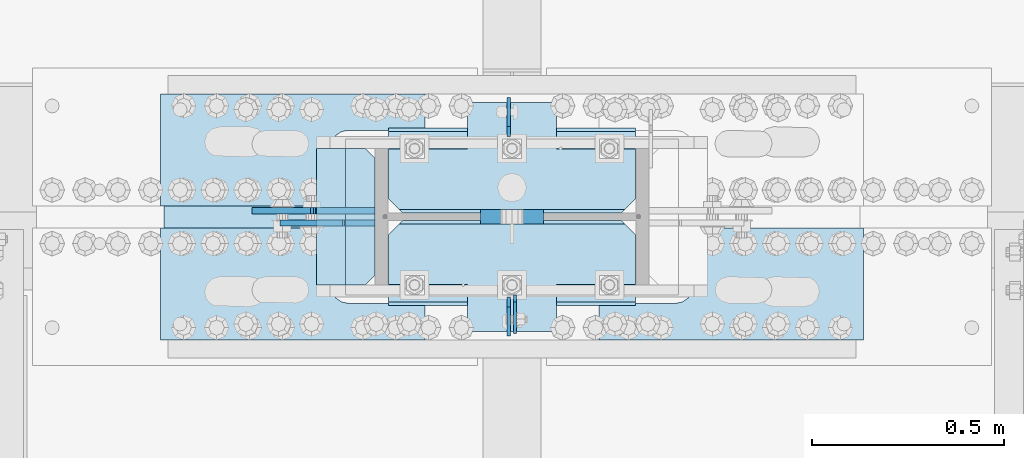
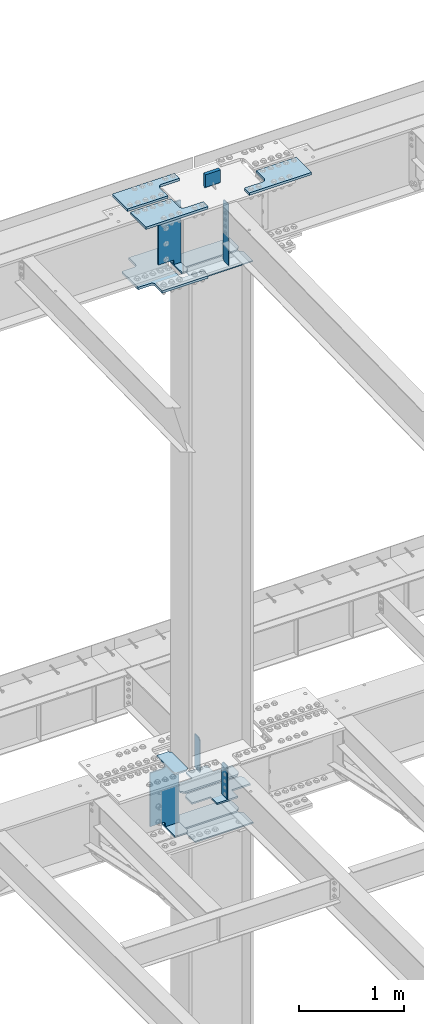
# One storey, part 1608 of 1763: 19 plates, 5 elements without a shape of their own.
"""IFC2X3 building model written with IfcOpenShell, lengths in millimetres."""

from ifc_helpers import new_model, si_unit, frame, origin_with_axes, place, context, subcontext, project, spatial, faceted_brep, material, type_object, element, aggregate, save


model = new_model("IFC2X3")

# Units and contexts
model_context = context("Model", 3, precision=1e-05, world=origin_with_axes())
body_context = subcontext(model_context, "Body", "Model", "MODEL_VIEW")
ifc_project = project(units=[si_unit("LENGTHUNIT", "METRE", prefix="MILLI"), si_unit("AREAUNIT", "SQUARE_METRE"), si_unit("VOLUMEUNIT", "CUBIC_METRE"), si_unit("MASSUNIT", "GRAM", prefix="KILO"), si_unit("TIMEUNIT", "SECOND"), si_unit("PLANEANGLEUNIT", "RADIAN"), si_unit("SOLIDANGLEUNIT", "STERADIAN"), si_unit("THERMODYNAMICTEMPERATUREUNIT", "DEGREE_CELSIUS"), si_unit("LUMINOUSINTENSITYUNIT", "LUMEN")], contexts=[model_context])

# Site, building, storey
site_placement = place(None, origin_with_axes())
site = spatial("IfcSite", under=ifc_project, at=site_placement, CompositionType="ELEMENT")
building_placement = place(site_placement, origin_with_axes())
building = spatial("IfcBuilding", under=site, at=building_placement, Name="Undefined", CompositionType="ELEMENT")
storey_placement = place(building_placement, origin_with_axes())
storey = spatial("IfcBuildingStorey", under=building, at=storey_placement, Name="Undefined", CompositionType="ELEMENT", Elevation=0.0)

# Assembly, plates
assembly_1_placement = place(storey_placement, origin_with_axes())
assembly_1 = element("IfcElementAssembly", 1, at=assembly_1_placement, inside=storey, Name="COLUMN", AssemblyPlace="NOTDEFINED", PredefinedType="RIGID_FRAME")
ifc_material_1 = material(Name="STEEL/A36")
plate_type_1 = type_object("IfcPlateType", PredefinedType="NOTDEFINED")
plate_1_placement = place(assembly_1_placement, frame((-72483.1002737632, 51917.5999999994, 11718.1532534164), z_axis=(0.0, -1.0, 0.0), x_axis=(0.0, 0.0, -1.0)))
plate_1 = element("IfcPlate", 2, at=plate_1_placement, type_object=plate_type_1, material=ifc_material_1, Name="PLATE", context=body_context, shape_type="Brep", body=[
    faceted_brep([(0.0, -3.96899999999732, 19.0499992370605), (-1.18234311230481e-11, -3.96900000000096, 101.599998474121), (-1.18234311230481e-11, 3.96900000000096, 101.599998474121), (0.0, 3.96899999999732, 19.0499992370605), (719.137512207031, -3.96899999999732, 101.599998474121), (719.137512207031, 3.96899999999732, 101.599998474121), (719.137512207031, -3.96899999999732, 19.0499992370605), (719.137512207031, 3.96899999999732, 19.0499992370605), (700.087512969971, -3.96899999999732, 0.0), (700.087512969971, 3.96899999999732, 0.0), (19.0499992370605, -3.96899999999732, 0.0), (19.0499992370605, 3.96899999999732, 0.0)], [[[0, 1, 2, 3]], [[1, 4, 5, 2]], [[4, 6, 7, 5]], [[6, 8, 9, 7]], [[8, 10, 11, 9]], [[10, 0, 3, 11]], [[5, 7, 9, 11, 3, 2]], [[10, 8, 6, 4, 1, 0]]]),
])
ifc_material_2 = material(Name="STEEL/A572-GR.50")
plate_type_2 = type_object("IfcPlateType", PredefinedType="NOTDEFINED")
plate_2_placement = place(assembly_1_placement, frame((-72499.7685236984, 51911.25, 5165.725), z_axis=(0.0, -1.0, 0.0), x_axis=(0.0, 0.0, -1.0)))
plate_2 = element("IfcPlate", 3, at=plate_2_placement, type_object=plate_type_2, material=ifc_material_2, Name="PLATE", context=body_context, shape_type="Brep", body=[
    faceted_brep([(25.3999996185303, -4.76250000000073, 0.0), (0.0, -4.76250000000073, 25.3999996185303), (0.0, 4.76250000000073, 25.3999996185303), (25.3999996185303, 4.76250000000073, 0.0), (1.45519152283669e-11, -4.76250000000448, 101.60001373291), (390.524993896484, -4.76249999999709, 101.599998474121), (390.524993896484, 4.76249999999709, 101.599998474121), (0.0, 4.76250000000243, 101.60001373291), (390.524993896484, -4.76249999999709, 0.0), (390.524993896484, 4.76249999999709, 0.0)], [[[0, 1, 2, 3]], [[4, 5, 6, 7]], [[5, 8, 9, 6]], [[9, 8, 0, 3]], [[7, 6, 9, 3, 2]], [[4, 7, 2, 1]], [[8, 5, 4, 1, 0]]]),
])
plate_3_placement = place(assembly_1_placement, frame((-72499.7685236984, 52330.35, 5165.725), z_axis=(0.0, 1.0, 0.0), x_axis=(0.0, 0.0, -1.0)))
plate_3 = element("IfcPlate", 4, at=plate_3_placement, type_object=plate_type_2, material=ifc_material_2, Name="PLATE", context=body_context, shape_type="Brep", body=[
    faceted_brep([(25.3999996185303, -4.76250000000073, 0.0), (0.0, -4.76250000000073, 25.3999996185303), (0.0, 4.76250000000073, 25.3999996185303), (25.3999996185303, 4.76250000000073, 0.0), (1.45519152283669e-11, -4.76250000000448, 101.60001373291), (390.524993896484, -4.76249999999709, 101.599998474121), (390.524993896484, 4.76249999999709, 101.599998474121), (0.0, 4.76250000000243, 101.60001373291), (390.524993896484, -4.76249999999709, 0.0), (390.524993896484, 4.76249999999709, 0.0)], [[[0, 1, 2, 3]], [[4, 5, 6, 7]], [[5, 8, 9, 6]], [[9, 8, 0, 3]], [[7, 6, 9, 3, 2]], [[4, 7, 2, 1]], [[8, 5, 4, 1, 0]]]),
])
ifc_material_3 = material(Name="STEEL/A572-50")
plate_type_3 = type_object("IfcPlateType", PredefinedType="NOTDEFINED")
plate_4_placement = place(assembly_1_placement, frame((-73000.6247736983, 52298.6, 4427.5375), z_axis=(1.0, 0.0, 0.0), x_axis=(0.0, -1.0, 0.0)))
plate_4 = element("IfcPlate", 5, at=plate_4_placement, type_object=plate_type_3, material=ifc_material_3, Name="PLATE", context=body_context, shape_type="Brep", body=[
    faceted_brep([(-7.27595761418343e-12, -7.9375, 0.0), (0.0, -7.9375, 126.999994277954), (0.0, 7.9375, 126.999994277954), (-7.27595761418343e-12, 7.9375, 0.0), (25.3999996185303, -7.9375, 152.399993896484), (25.3999996185303, 7.9375, 152.399993896484), (330.200006484985, -7.9375, 152.399993896484), (330.200006484985, 7.9375, 152.399993896484), (355.600006103516, -7.9375, 126.999994277954), (355.600006103516, 7.9375, 126.999994277954), (355.600006103516, -7.9375, 0.0), (355.600006103516, 7.9375, 0.0)], [[[0, 1, 2, 3]], [[1, 4, 5, 2]], [[4, 6, 7, 5]], [[6, 8, 9, 7]], [[8, 10, 11, 9]], [[10, 0, 3, 11]], [[5, 7, 9, 11, 3, 2]], [[10, 8, 6, 4, 1, 0]]]),
])
plate_5_placement = place(assembly_1_placement, frame((-73000.6247736983, 52298.6, 5157.7875), z_axis=(1.0, 0.0, 0.0), x_axis=(0.0, -1.0, 0.0)))
plate_5 = element("IfcPlate", 6, at=plate_5_placement, type_object=plate_type_3, material=ifc_material_3, Name="PLATE", context=body_context, shape_type="Brep", body=[
    faceted_brep([(-7.27595761418343e-12, -7.9375, 0.0), (0.0, -7.9375, 126.999994277954), (0.0, 7.9375, 126.999994277954), (-7.27595761418343e-12, 7.9375, 0.0), (25.3999996185303, -7.9375, 152.399993896484), (25.3999996185303, 7.9375, 152.399993896484), (330.200006484985, -7.9375, 152.399993896484), (330.200006484985, 7.9375, 152.399993896484), (355.600006103516, -7.9375, 126.999994277954), (355.600006103516, 7.9375, 126.999994277954), (355.600006103516, -7.9375, 0.0), (355.600006103516, 7.9375, 0.0)], [[[0, 1, 2, 3]], [[1, 4, 5, 2]], [[4, 6, 7, 5]], [[6, 8, 9, 7]], [[8, 10, 11, 9]], [[10, 0, 3, 11]], [[5, 7, 9, 11, 3, 2]], [[10, 8, 6, 4, 1, 0]]]),
])
plate_type_4 = type_object("IfcPlateType", PredefinedType="NOTDEFINED")
plate_6_placement = place(assembly_1_placement, frame((-72813.2997736984, 51889.025, 4335.4625), z_axis=(1.0, 0.0, 0.0), x_axis=(0.0, 1.0, 0.0)))
plate_6 = element("IfcPlate", 7, at=plate_6_placement, type_object=plate_type_4, material=ifc_material_3, Name="HORIZONTAL SHEAR PLAT", context=body_context, shape_type="Brep", body=[
    faceted_brep([(-7.27595761418343e-12, -7.9375, 0.0), (0.0, -7.9375, 644.524963378906), (0.0, 7.9375, 644.524963378906), (-7.27595761418343e-12, 7.9375, 0.0), (184.150001525879, -7.9375, 644.524963378906), (184.150001525879, 7.9375, 644.524963378906), (222.25, -7.9375, 606.424964904785), (222.25, 7.9375, 606.424964904785), (222.25, -7.9375, 38.0999984741211), (222.25, 7.9375, 38.0999984741211), (184.150001525879, -7.9375, 0.0), (184.150001525879, 7.9375, 0.0)], [[[0, 1, 2, 3]], [[1, 4, 5, 2]], [[4, 6, 7, 5]], [[6, 8, 9, 7]], [[8, 10, 11, 9]], [[10, 0, 3, 11]], [[5, 7, 9, 11, 3, 2]], [[10, 8, 6, 4, 1, 0]]]),
])
plate_7_placement = place(assembly_1_placement, frame((-72813.2997736984, 52352.575, 4335.4625), z_axis=(1.0, 0.0, 0.0), x_axis=(0.0, -1.0, 0.0)))
plate_7 = element("IfcPlate", 8, at=plate_7_placement, type_object=plate_type_4, material=ifc_material_3, Name="HORIZONTAL SHEAR PLAT", context=body_context, shape_type="Brep", body=[
    faceted_brep([(-7.27595761418343e-12, -7.9375, 0.0), (0.0, -7.9375, 644.524963378906), (0.0, 7.9375, 644.524963378906), (-7.27595761418343e-12, 7.9375, 0.0), (184.150001525879, -7.9375, 644.524963378906), (184.150001525879, 7.9375, 644.524963378906), (222.25, -7.9375, 606.424964904785), (222.25, 7.9375, 606.424964904785), (222.25, -7.9375, 38.0999984741211), (222.25, 7.9375, 38.0999984741211), (184.150001525879, -7.9375, 0.0), (184.150001525879, 7.9375, 0.0)], [[[0, 1, 2, 3]], [[1, 4, 5, 2]], [[4, 6, 7, 5]], [[6, 8, 9, 7]], [[8, 10, 11, 9]], [[10, 0, 3, 11]], [[5, 7, 9, 11, 3, 2]], [[10, 8, 6, 4, 1, 0]]]),
])
plate_type_5 = type_object("IfcPlateType", PredefinedType="NOTDEFINED")
plate_8_placement = place(assembly_1_placement, frame((-72168.7747736983, 51898.55, 10887.0749917654), z_axis=(-1.0, 0.0, 0.0), x_axis=(0.0, 1.0, 0.0)))
plate_8 = element("IfcPlate", 9, at=plate_8_placement, type_object=plate_type_5, material=ifc_material_3, Name="PLATE", context=body_context, shape_type="Brep", body=[
    faceted_brep([(0.0, -6.34999999999491, 1.45519152283669e-11), (0.0, -6.35000000000036, 644.525024414062), (0.0, 6.35000000000036, 644.525024414062), (0.0, 6.34999999999491, -2.91038304567337e-11), (174.625007629395, -6.35000000000036, 644.525024414062), (174.625007629395, 6.35000000000036, 644.525024414062), (212.725006103516, -6.35000000000036, 606.425025939941), (212.725006103516, 6.35000000000036, 606.425025939941), (212.725006103516, -6.35000000000036, 38.0999984741211), (212.725006103516, 6.35000000000036, 38.0999984741211), (174.625007629395, -6.35000000000036, 0.0), (174.625007629395, 6.35000000000036, 0.0)], [[[0, 1, 2, 3]], [[1, 4, 5, 2]], [[4, 6, 7, 5]], [[6, 8, 9, 7]], [[8, 10, 11, 9]], [[10, 0, 3, 11]], [[5, 7, 9, 11, 3, 2]], [[10, 8, 6, 4, 1, 0]]]),
])
plate_9_placement = place(assembly_1_placement, frame((-72168.7747736983, 52130.325, 10887.0749917654), z_axis=(-1.0, 0.0, 0.0), x_axis=(0.0, 1.0, 0.0)))
plate_9 = element("IfcPlate", 10, at=plate_9_placement, type_object=plate_type_5, material=ifc_material_3, Name="PLATE", context=body_context, shape_type="Brep", body=[
    faceted_brep([(0.0, -6.34999999999854, 38.0999984741211), (0.0, -6.35000000000036, 606.425025939941), (0.0, 6.35000000000036, 606.425025939941), (0.0, 6.34999999999854, 38.0999984741211), (38.0999984741211, -6.35000000000036, 644.525024414062), (38.0999984741211, 6.35000000000036, 644.525024414062), (212.725006103516, -6.35000000000036, 644.525024414062), (212.725006103516, 6.35000000000036, 644.525024414062), (212.725006103516, -6.35000000000036, 0.0), (212.725006103516, 6.35000000000036, 0.0), (38.0999984741211, -6.34999999999854, 0.0), (38.0999984741211, 6.34999999999854, 0.0)], [[[0, 1, 2, 3]], [[1, 4, 5, 2]], [[4, 6, 7, 5]], [[6, 8, 9, 7]], [[8, 10, 11, 9]], [[10, 0, 3, 11]], [[5, 7, 9, 11, 3, 2]], [[10, 8, 6, 4, 1, 0]]]),
])
plate_type_6 = type_object("IfcPlateType", PredefinedType="NOTDEFINED")
plate_10_placement = place(assembly_1_placement, frame((-72168.7747736983, 51822.35, 4749.8), z_axis=(-1.0, 0.0, 0.0), x_axis=(0.0, 1.0, 0.0)))
plate_10 = element("IfcPlate", 11, at=plate_10_placement, type_object=plate_type_6, material=ifc_material_3, Name="PLATE", context=body_context, shape_type="Brep", body=[
    faceted_brep([(288.924987792969, -7.65116965339985e-07, 606.425025939941), (279.399988558085, -9.52499999999964, 615.950025174825), (279.399988558085, -9.52499999999964, 28.5749992392375), (288.924987792969, -7.65116965339985e-07, 38.0999984741211), (250.824989318848, -9.52499999999964, 644.525024414062), (250.824989318848, 9.52499999999964, 644.525024414062), (122.237487792991, 9.52499999999964, 644.525024414062), (122.237487792991, -9.52499999999964, 644.525015258769), (122.237487792983, 9.52499999999964, 438.14999999998), (122.237487792983, -9.52499999999964, 438.14999999998), (0.0, 9.52499999999964, 438.149991923026), (0.0, -9.52499999999964, 438.149991923026), (0.0, 9.52499999999964, 206.375007181632), (0.0, -9.52499999999964, 206.375007181632), (250.824989318848, 9.52499999999964, 0.0), (250.824989318848, -9.52499999999964, 0.0), (122.237487792998, -9.52499999999964, 0.0), (122.237487792998, 9.52499999999964, 0.0), (122.237487793005, -9.52499999999964, 206.375015258775), (122.237487793005, 9.52499999999964, 206.375015258775), (288.924987792969, 9.52499999999964, 606.425025939941), (288.924987792969, 9.52499999999964, 38.0999984741211)], [[[0, 1, 2, 3]], [[4, 5, 6, 7]], [[7, 6, 8, 9]], [[9, 8, 10, 11]], [[11, 10, 12, 13]], [[14, 15, 16, 17]], [[18, 19, 17, 16]], [[13, 12, 19, 18]], [[10, 8, 6, 5, 20, 21, 14, 17, 19, 12]], [[21, 20, 0, 3]], [[15, 14, 21, 3, 2]], [[4, 7, 9, 11, 13, 18, 16, 15, 2, 1]], [[20, 5, 4, 1, 0]]]),
])
plate_11_placement = place(assembly_1_placement, frame((-72168.7747736983, 52130.325, 4749.8), z_axis=(-1.0, 0.0, 0.0), x_axis=(0.0, 1.0, 0.0)))
plate_11 = element("IfcPlate", 12, at=plate_11_placement, type_object=plate_type_6, material=ifc_material_3, Name="PLATE", context=body_context, shape_type="Brep", body=[
    faceted_brep([(9.52499923488358, -9.52499999999964, 615.950025174825), (0.0, -7.65116965339985e-07, 606.425025939941), (0.0, 0.0, 38.0999984741211), (9.52499923488358, -9.52499999999964, 28.5749992392375), (288.924987792961, -9.52499999999964, 438.14999999998), (288.924987792969, 9.52499999999964, 438.14999999998), (166.687499999833, 9.52499999999964, 438.149991923055), (166.687499999833, -9.52499999999964, 438.149991923055), (288.924987792983, -9.52499999999964, 206.375015258775), (288.924987792969, 9.52499999999964, 206.375015258775), (38.0999984741211, -9.52500000000146, 0.0), (38.0999984741211, 9.52500000000146, 0.0), (166.6875, 9.52499999999964, 0.0), (166.6875, -9.52499999999964, 0.0), (166.687503076391, 9.52499999999964, 206.375007181618), (166.687503076391, -9.52499999999964, 206.375007181618), (0.0, 9.52500000000146, 38.0999984741211), (0.0, 9.52499999999964, 606.425025939941), (38.0999984741211, 9.52499999999964, 644.525024414062), (166.687503076224, 9.52499999999964, 644.525024414062), (166.687503076224, -9.52499999999964, 644.525024414062), (38.0999984741211, -9.52499999999964, 644.525024414062)], [[[0, 1, 2, 3]], [[4, 5, 6, 7]], [[5, 4, 8, 9]], [[10, 11, 12, 13]], [[13, 12, 14, 15]], [[8, 15, 14, 9]], [[12, 11, 16, 17, 18, 19, 6, 5, 9, 14]], [[20, 7, 6, 19]], [[18, 21, 20, 19]], [[10, 13, 15, 8, 4, 7, 20, 21, 0, 3]], [[16, 11, 10, 3, 2]], [[17, 16, 2, 1]], [[21, 18, 17, 1, 0]]]),
])

# Assembly, plate
assembly_2_placement = place(storey_placement, origin_with_axes())
assembly_2 = element("IfcElementAssembly", 13, at=assembly_2_placement, inside=storey, Name="PLATE", AssemblyPlace="NOTDEFINED", PredefinedType="RIGID_FRAME")
plate_type_7 = type_object("IfcPlateType", PredefinedType="NOTDEFINED")
plate_12_placement = place(assembly_2_placement, frame((-72718.0497736984, 52441.4750002128, 10955.3374917654), z_axis=(0.0, -1.0, 0.0), x_axis=(-1.0, 0.0, 0.0)))
plate_12 = element("IfcPlate", 14, at=plate_12_placement, type_object=plate_type_7, material=ifc_material_3, Name="PLATE", context=body_context, shape_type="Brep", body=[
    faceted_brep([(0.0, -14.2875000000058, 0.0), (0.0, -14.2875000000004, 95.25), (0.0, 14.2875000000004, 95.25), (0.0, 14.2875000000058, 0.0), (209.550006866455, -14.2875000000004, 95.25), (209.550006866455, 14.2875000000004, 95.25), (220.342425159237, -14.2875000000004, 96.9593511310522), (220.342425159237, 14.2875000000004, 96.9593511310522), (230.078406354325, -14.2875000000004, 101.920081325748), (230.078406354325, 14.2875000000004, 101.920081325748), (237.804924777767, -14.2875000000004, 109.646599749191), (237.804924777767, 14.2875000000004, 109.646599749191), (242.765654972463, -14.2875000000004, 119.382580944279), (242.765654972463, 14.2875000000004, 119.382580944279), (244.475006103516, -14.2875000000004, 130.174999237061), (244.475006103516, 14.2875000000004, 130.174999237061), (244.475006103516, -14.2875000000004, 511.174976348877), (244.475006103516, 14.2875000000004, 511.174976348877), (242.765654972463, -14.2875000000004, 521.967394641659), (242.765654972463, 14.2875000000004, 521.967394641659), (237.804924777767, -14.2875000000004, 531.703375836747), (237.804924777767, 14.2875000000004, 531.703375836747), (230.078406354325, -14.2875000000004, 539.429894260189), (230.078406354325, 14.2875000000004, 539.429894260189), (220.342425159237, -14.2875000000004, 544.390624454885), (220.342425159237, 14.2875000000004, 544.390624454885), (209.550006866455, -14.2875000000004, 546.099975585938), (209.550006866455, 14.2875000000004, 546.099975585938), (0.0, -14.2875000000004, 546.099975585938), (0.0, 14.2875000000004, 546.099975585938), (0.0, -14.2875000000004, 641.349975585938), (0.0, 14.2875000000004, 641.349975585938), (508.0, -14.2875000000004, 641.349975585938), (508.0, 14.2875000000004, 641.349975585938), (508.0, -14.2875000000004, 511.174999237061), (508.0, 14.2875000000004, 511.174999237061), (509.709351131052, -14.2875000000004, 500.382580944279), (509.709351131052, 14.2875000000004, 500.382580944279), (514.670081325748, -14.2875000000004, 490.646599749191), (514.670081325748, 14.2875000000004, 490.646599749191), (522.396599749191, -14.2875000000004, 482.920081325748), (522.396599749191, 14.2875000000004, 482.920081325748), (532.132580944279, -14.2875000000004, 477.959351131052), (532.132580944279, 14.2875000000004, 477.959351131052), (542.924999237061, -14.2875000000004, 476.25), (542.924999237061, 14.2875000000004, 476.25), (679.450012207031, -14.2875000000004, 476.25), (679.450012207031, 14.2875000000004, 476.25), (679.450012207031, -14.2875000000004, 165.100006103516), (679.450012207031, 14.2875000000004, 165.100006103516), (542.924999237061, -14.2875000000004, 165.100006103516), (542.924999237061, 14.2875000000004, 165.100006103516), (532.132580944279, -14.2875000000004, 163.390654972463), (532.132580944279, 14.2875000000004, 163.390654972463), (522.396599749191, -14.2875000000004, 158.429924777767), (522.396599749191, 14.2875000000004, 158.429924777767), (514.670081325748, -14.2875000000004, 150.703406354325), (514.670081325748, 14.2875000000004, 150.703406354325), (509.709351131052, -14.2875000000004, 140.967425159237), (509.709351131052, 14.2875000000004, 140.967425159237), (508.0, -14.2875000000004, 130.175006866455), (508.0, 14.2875000000004, 130.175006866455), (508.0, -14.2875000000004, 0.0), (508.0, 14.2875000000004, 0.0)], [[[0, 1, 2, 3]], [[1, 4, 5, 2]], [[4, 6, 7, 5]], [[6, 8, 9, 7]], [[8, 10, 11, 9]], [[10, 12, 13, 11]], [[12, 14, 15, 13]], [[14, 16, 17, 15]], [[16, 18, 19, 17]], [[18, 20, 21, 19]], [[20, 22, 23, 21]], [[22, 24, 25, 23]], [[24, 26, 27, 25]], [[26, 28, 29, 27]], [[28, 30, 31, 29]], [[30, 32, 33, 31]], [[32, 34, 35, 33]], [[34, 36, 37, 35]], [[36, 38, 39, 37]], [[38, 40, 41, 39]], [[40, 42, 43, 41]], [[42, 44, 45, 43]], [[44, 46, 47, 45]], [[46, 48, 49, 47]], [[48, 50, 51, 49]], [[50, 52, 53, 51]], [[52, 54, 55, 53]], [[54, 56, 57, 55]], [[56, 58, 59, 57]], [[58, 60, 61, 59]], [[60, 62, 63, 61]], [[62, 0, 3, 63]], [[5, 7, 9, 11, 13, 15, 17, 19, 21, 23, 25, 27, 29, 31, 33, 35, 37, 39, 41, 43, 45, 47, 49, 51, 53, 55, 57, 59, 61, 63, 3, 2]], [[62, 60, 58, 56, 54, 52, 50, 48, 46, 44, 42, 40, 38, 36, 34, 32, 30, 28, 26, 24, 22, 20, 18, 16, 14, 12, 10, 8, 6, 4, 1, 0]]]),
])
aggregate(assembly_2, [plate_12])

assembly_3_placement = place(storey_placement, origin_with_axes())
assembly_3 = element("IfcElementAssembly", 15, at=assembly_3_placement, inside=storey, Name="TOP PLATE", AssemblyPlace="NOTDEFINED", PredefinedType="RIGID_FRAME")
plate_type_8 = type_object("IfcPlateType", PredefinedType="NOTDEFINED")
plate_13_placement = place(assembly_3_placement, frame((-73407.0247736984, 52149.3750002128, 11761.7874917654), z_axis=(0.0, 1.0, 0.0), x_axis=(1.0, 0.0, 0.0)))
plate_13 = element("IfcPlate", 16, at=plate_13_placement, type_object=plate_type_8, material=ifc_material_3, Name="TOP PLATE", context=body_context, shape_type="Brep", body=[
    faceted_brep([(0.0, -14.2875000000058, 0.0), (0.0, -14.2875000000004, 292.100006103516), (0.0, 14.2875000000004, 292.100006103516), (0.0, 14.2875000000058, 0.0), (688.974975585938, -14.2875000000004, 292.100006103516), (688.974975585938, 14.2875000000004, 292.100006103516), (688.974975585938, -14.2875000000004, 196.850006103516), (688.974975585938, 14.2875000000004, 196.850006103516), (488.950000762939, -14.2875000000004, 196.850006103516), (488.950000762939, 14.2875000000004, 196.850006103516), (471.939721902345, -14.2875000000004, 193.466451265565), (471.939721902345, 14.2875000000004, 193.466451265565), (457.519103799721, -14.2875000000004, 183.830902303795), (457.519103799721, 14.2875000000004, 183.830902303795), (447.88355483795, -14.2875000000004, 169.410284201171), (447.88355483795, 14.2875000000004, 169.410284201171), (444.5, -14.2875000000004, 152.400005340576), (444.5, 14.2875000000004, 152.400005340576), (444.5, -14.2875000000004, 0.0), (444.5, 14.2875000000004, 0.0)], [[[0, 1, 2, 3]], [[1, 4, 5, 2]], [[4, 6, 7, 5]], [[6, 8, 9, 7]], [[8, 10, 11, 9]], [[10, 12, 13, 11]], [[12, 14, 15, 13]], [[14, 16, 17, 15]], [[16, 18, 19, 17]], [[18, 0, 3, 19]], [[5, 7, 9, 11, 13, 15, 17, 19, 3, 2]], [[18, 16, 14, 12, 10, 8, 6, 4, 1, 0]]]),
])
aggregate(assembly_3, [plate_13])

assembly_4_placement = place(storey_placement, origin_with_axes())
assembly_4 = element("IfcElementAssembly", 17, at=assembly_4_placement, inside=storey, Name="TOP PLATE", AssemblyPlace="NOTDEFINED", PredefinedType="RIGID_FRAME")
plate_14_placement = place(assembly_4_placement, frame((-72962.5247736984, 52092.2250002128, 11761.7874917654), z_axis=(0.0, -1.0, 0.0), x_axis=(-1.0, 0.0, 0.0)))
plate_14 = element("IfcPlate", 18, at=plate_14_placement, type_object=plate_type_8, material=ifc_material_3, Name="TOP PLATE", context=body_context, shape_type="Brep", body=[
    faceted_brep([(0.0, -14.2875000000058, 0.0), (0.0, -14.2875000000004, 152.400001525879), (0.0, 14.2875000000004, 152.400001525879), (0.0, 14.2875000000058, 0.0), (-3.38355483795021, -14.2875000000004, 169.410284201171), (-3.38355483795021, 14.2875000000004, 169.410284201171), (-13.0191037997211, -14.2875000000004, 183.830902303795), (-13.0191037997211, 14.2875000000004, 183.830902303795), (-27.4397219023449, -14.2875000000004, 193.466451265565), (-27.4397219023449, 14.2875000000004, 193.466451265565), (-44.4500007629395, -14.2875000000004, 196.850006103516), (-44.4500007629395, 14.2875000000004, 196.850006103516), (-244.475006103516, -14.2875000000004, 196.850006103516), (-244.475006103516, 14.2875000000004, 196.850006103516), (-244.475006103516, -14.2875000000004, 292.100006103516), (-244.475006103516, 14.2875000000004, 292.100006103516), (444.5, -14.2875000000004, 292.100006103516), (444.5, 14.2875000000004, 292.100006103516), (444.5, -14.2875000000004, 0.0), (444.5, 14.2875000000004, 0.0)], [[[0, 1, 2, 3]], [[1, 4, 5, 2]], [[4, 6, 7, 5]], [[6, 8, 9, 7]], [[8, 10, 11, 9]], [[10, 12, 13, 11]], [[12, 14, 15, 13]], [[14, 16, 17, 15]], [[16, 18, 19, 17]], [[18, 0, 3, 19]], [[5, 7, 9, 11, 13, 15, 17, 19, 3, 2]], [[18, 16, 14, 12, 10, 8, 6, 4, 1, 0]]]),
])
aggregate(assembly_4, [plate_14])

assembly_5_placement = place(storey_placement, origin_with_axes())
assembly_5 = element("IfcElementAssembly", 19, at=assembly_5_placement, inside=storey, Name="TOP PLATE", AssemblyPlace="NOTDEFINED", PredefinedType="RIGID_FRAME")
plate_15_placement = place(assembly_5_placement, frame((-71575.0497736984, 52092.2250002128, 11761.7874917654), z_axis=(0.0, -1.0, 0.0), x_axis=(-1.0, 0.0, 0.0)))
plate_15 = element("IfcPlate", 20, at=plate_15_placement, type_object=plate_type_8, material=ifc_material_3, Name="TOP PLATE", context=body_context, shape_type="Brep", body=[
    faceted_brep([(0.0, -14.2875000000058, 0.0), (0.0, -14.2875000000004, 292.100006103516), (0.0, 14.2875000000004, 292.100006103516), (0.0, 14.2875000000058, 0.0), (688.974975585938, -14.2875000000004, 292.100006103516), (688.974975585938, 14.2875000000004, 292.100006103516), (688.974975585938, -14.2875000000004, 196.850006103516), (688.974975585938, 14.2875000000004, 196.850006103516), (488.950000762939, -14.2875000000004, 196.850006103516), (488.950000762939, 14.2875000000004, 196.850006103516), (471.939721902345, -14.2875000000004, 193.466451265565), (471.939721902345, 14.2875000000004, 193.466451265565), (457.519103799721, -14.2875000000004, 183.830902303795), (457.519103799721, 14.2875000000004, 183.830902303795), (447.88355483795, -14.2875000000004, 169.410284201171), (447.88355483795, 14.2875000000004, 169.410284201171), (444.5, -14.2875000000004, 152.400005340576), (444.5, 14.2875000000004, 152.400005340576), (444.5, -14.2875000000004, 0.0), (444.5, 14.2875000000004, 0.0)], [[[0, 1, 2, 3]], [[1, 4, 5, 2]], [[4, 6, 7, 5]], [[6, 8, 9, 7]], [[8, 10, 11, 9]], [[10, 12, 13, 11]], [[12, 14, 15, 13]], [[14, 16, 17, 15]], [[16, 18, 19, 17]], [[18, 0, 3, 19]], [[5, 7, 9, 11, 13, 15, 17, 19, 3, 2]], [[18, 16, 14, 12, 10, 8, 6, 4, 1, 0]]]),
])
aggregate(assembly_5, [plate_15])

# Plate
plate_type_9 = type_object("IfcPlateType", PredefinedType="NOTDEFINED")
plate_16_placement = place(assembly_1_placement, frame((-72848.2247736984, 51943.0, 10980.7374917654), z_axis=(-1.0, 0.0, 0.0), x_axis=(0.0, 1.0, 0.0)))
plate_16 = element("IfcPlate", 21, at=plate_16_placement, type_object=plate_type_9, material=ifc_material_3, Name="BRIDGE PLATE", context=body_context, shape_type="Brep", body=[
    faceted_brep([(0.0, -11.1124999999993, 25.3999996185303), (0.0, -11.1124999999993, 76.1999969482422), (0.0, 11.1124999999993, 76.1999969482422), (0.0, 11.1124999999993, 25.3999996185303), (355.600006103516, -11.1124999999993, 76.1999969482422), (355.600006103516, 11.1124999999993, 76.1999969482422), (355.600006103516, -11.1124999999993, 25.3999996185303), (355.600006103516, 11.1124999999993, 25.3999996185303), (330.200006484985, -11.1124999999993, 0.0), (330.200006484985, 11.1124999999993, 0.0), (25.3999996185303, -11.1124999999993, 0.0), (25.3999996185303, 11.1124999999993, 0.0)], [[[0, 1, 2, 3]], [[1, 4, 5, 2]], [[4, 6, 7, 5]], [[6, 8, 9, 7]], [[8, 10, 11, 9]], [[10, 0, 3, 11]], [[5, 7, 9, 11, 3, 2]], [[10, 8, 6, 4, 1, 0]]]),
])

plate_type_10 = type_object("IfcPlateType", PredefinedType="NOTDEFINED")
plate_17_placement = place(assembly_1_placement, frame((-73095.8747736984, 52104.9250002128, 11045.8249917654), z_axis=(1.0, 0.0, 0.0), x_axis=(0.0, 0.0, 1.0)))
plate_17 = element("IfcPlate", 22, at=plate_17_placement, type_object=plate_type_10, material=ifc_material_3, Name="SHEAR TAB", context=body_context, shape_type="Brep", body=[
    faceted_brep([(-7.27595761418343e-12, -7.9375, 0.0), (0.0, -7.9375, 158.749997138977), (0.0, 7.9375, 158.749997138977), (-7.27595761418343e-12, 7.9375, 0.0), (-0.966729922587547, -7.9375, 163.610076657023), (-0.966729922587547, 7.9375, 163.610076657023), (-3.71974382306507, -7.9375, 167.730253125177), (-3.71974382306507, 7.9375, 167.730253125177), (-7.83992029121873, -7.9375, 170.483267025651), (-7.83992029121873, 7.9375, 170.483267025651), (-12.6999998092651, -7.9375, 171.449996948242), (-12.6999998092651, 7.9375, 171.449996948242), (-53.9749984741211, -7.9375, 171.449996948242), (-53.9749984741211, 7.9375, 171.449996948242), (-53.9749984741211, -7.9375, 247.649993896484), (-53.9749984741211, 7.9375, 247.649993896484), (671.512451171875, -7.9375, 247.649993896484), (671.512451171875, 7.9375, 247.649993896484), (671.512451171875, -7.9375, 171.449996948242), (671.512451171875, 7.9375, 171.449996948242), (638.174975395203, -7.9375, 171.449996948242), (638.174975395203, 7.9375, 171.449996948242), (633.314895877156, -7.9375, 170.483267025651), (633.314895877156, 7.9375, 170.483267025651), (629.194719409003, -7.9375, 167.730253125177), (629.194719409003, 7.9375, 167.730253125177), (626.441705508525, -7.9375, 163.610076657023), (626.441705508525, 7.9375, 163.610076657023), (625.474975585938, -7.9375, 158.749997138977), (625.474975585938, 7.9375, 158.749997138977), (625.474975585938, -7.9375, 0.0), (625.474975585938, 7.9375, 0.0)], [[[0, 1, 2, 3]], [[1, 4, 5, 2]], [[4, 6, 7, 5]], [[6, 8, 9, 7]], [[8, 10, 11, 9]], [[10, 12, 13, 11]], [[12, 14, 15, 13]], [[14, 16, 17, 15]], [[16, 18, 19, 17]], [[18, 20, 21, 19]], [[20, 22, 23, 21]], [[22, 24, 25, 23]], [[24, 26, 27, 25]], [[26, 28, 29, 27]], [[28, 30, 31, 29]], [[30, 0, 3, 31]], [[5, 7, 9, 11, 13, 15, 17, 19, 21, 23, 25, 27, 29, 31, 3, 2]], [[30, 28, 26, 24, 22, 20, 18, 16, 14, 12, 10, 8, 6, 4, 1, 0]]]),
])

plate_type_11 = type_object("IfcPlateType", PredefinedType="NOTDEFINED")
plate_18_placement = place(assembly_1_placement, frame((-73168.8997736984, 52136.675, 4435.47562255859), z_axis=(1.0, 0.0, 0.0), x_axis=(0.0, 0.0, 1.0)))
plate_18 = element("IfcPlate", 23, at=plate_18_placement, type_object=plate_type_11, material=ifc_material_3, Name="SHEAR TAB", context=body_context, shape_type="Brep", body=[
    faceted_brep([(684.212475585938, -7.9375, 0.0), (684.212475585938, 7.9375, 0.0), (684.212475585938, 7.9375, 142.875009536743), (684.212475585938, -7.9375, 142.875009536743), (686.145935431114, 7.9375, 152.595168572821), (686.145935431114, -7.9375, 152.595168572821), (691.65196323207, 7.9375, 160.835521509129), (691.65196323207, -7.9375, 160.835521509129), (699.892316168377, 7.9375, 166.341549310091), (699.892316168377, -7.9375, 166.341549310091), (709.612475204468, 7.9375, 168.275009155273), (709.612475204468, -7.9375, 168.275009155273), (712.787475585938, -7.9375, 168.275009155273), (712.787475585938, 7.9375, 168.275009155273), (58.7375022888209, -7.9375, 142.875012588498), (58.7375022888209, 7.9375, 142.875012588498), (58.7375022888209, 7.9375, 0.0), (58.7375022888209, -7.9375, 0.0), (56.8040424436449, -7.9375, 152.595171624591), (56.8040424436449, 7.9375, 152.595171624591), (51.2980146426889, -7.9375, 160.835524560898), (51.2980146426889, 7.9375, 160.835524560898), (43.0576617063816, -7.9375, 166.341552361846), (43.0576617063816, 7.9375, 166.341552361846), (33.3375026702906, -7.9375, 168.275012207028), (33.3375026702906, 7.9375, 168.275012207028), (0.0, -7.9375, 168.275012207028), (0.0, 7.9375, 168.275012207028), (0.0, -7.9375, 320.674987792969), (0.0, 7.9375, 320.674987792969), (712.787475585938, -7.9375, 320.674987792969), (712.787475585938, 7.9375, 320.674987792969)], [[[0, 1, 2, 3]], [[3, 2, 4, 5]], [[5, 4, 6, 7]], [[7, 6, 8, 9]], [[9, 8, 10, 11]], [[12, 11, 10, 13]], [[14, 15, 16, 17]], [[18, 19, 15, 14]], [[20, 21, 19, 18]], [[22, 23, 21, 20]], [[24, 25, 23, 22]], [[26, 27, 25, 24]], [[28, 29, 27, 26]], [[28, 30, 31, 29]], [[31, 30, 12, 13]], [[8, 6, 4, 2, 1, 16, 15, 19, 21, 23, 25, 27, 29, 31, 13, 10]], [[17, 16, 1, 0]], [[30, 28, 26, 24, 22, 20, 18, 14, 17, 0, 3, 5, 7, 9, 11, 12]]]),
])

plate_type_12 = type_object("IfcPlateType", PredefinedType="NOTDEFINED")
plate_19_placement = place(assembly_1_placement, frame((-72408.4872721725, 52120.8, 11912.5999909009), z_axis=(0.0, 0.0, -1.0), x_axis=(-1.0, 0.0, 0.0)))
plate_19 = element("IfcPlate", 24, at=plate_19_placement, type_object=plate_type_12, material=ifc_material_3, Name="PLATE", context=body_context, shape_type="Brep", body=[
    faceted_brep([(0.0, 19.05, 146.049990844727), (-1.45519152283669e-11, 7.27595761418343e-12, 165.099990844727), (165.099990844727, 0.0, 165.099990844727), (165.099990844727, 19.05, 146.049990844727), (0.0, -19.05, 146.049990844727), (165.099990844727, -19.05, 146.049990844727), (0.0, 19.0500000000029, 0.0), (0.0, -19.0500000000029, 0.0), (165.10000190921, -19.0500000000029, 0.0), (165.10000190921, 19.0500000000029, 0.0)], [[[0, 1, 2, 3]], [[1, 4, 5, 2]], [[6, 7, 4, 1, 0]], [[5, 8, 9, 3, 2]], [[8, 7, 6, 9]], [[9, 6, 0, 3]], [[7, 8, 5, 4]]]),
])

aggregate(assembly_1, [plate_6, plate_7, plate_4, plate_5, plate_8, plate_9, plate_10, plate_11, plate_1, plate_17, plate_16, plate_2, plate_3, plate_18, plate_19])

save(model, "model.ifc")
